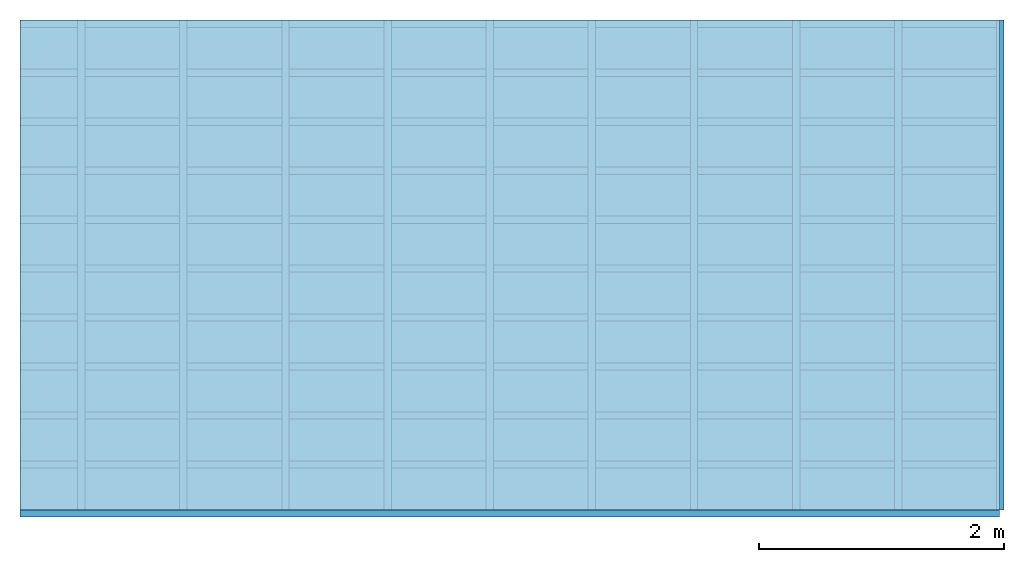
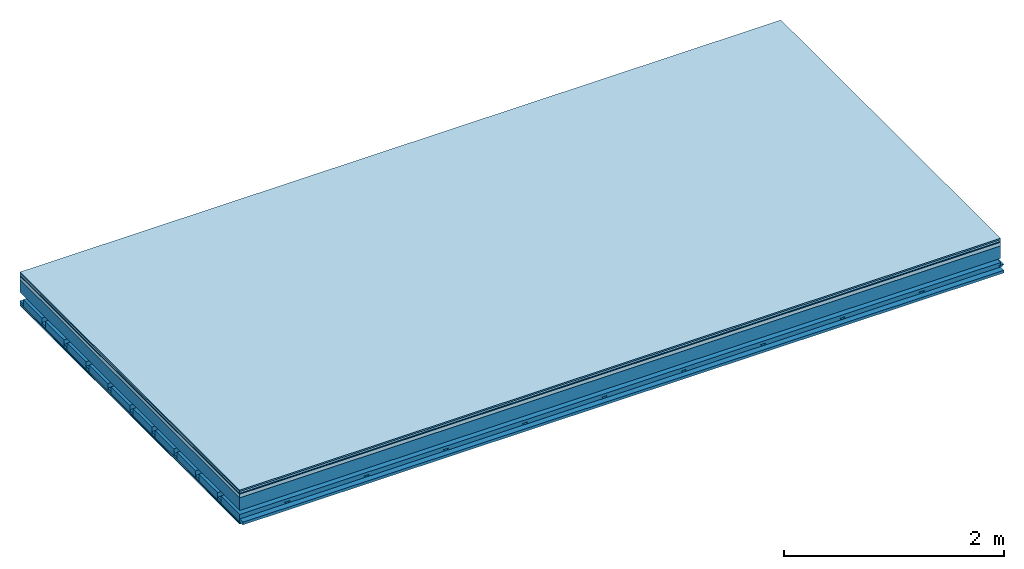
# One storey: 7 plates, 4 members, 1 element without a shape of its own.
"""IFC4 building model written with IfcOpenShell, lengths in metres."""

from ifc_helpers import new_model, si_unit, derived_unit, direction, frame, frame_2d, origin, origin_with_axes, place, context, project, spatial, polyline, rectangle, outline, extrude, material, layer, layer_set, type_object, element, aggregate, save


model = new_model("IFC4")

# Units and contexts
plan_context = context("Plan", 3, precision=1e-05, world=origin(), true_north=direction((0.0, 1.0)))
model_context = context("Model", 3, precision=1e-05, world=origin(), true_north=direction((0.0, 1.0)))
ifc_project = project(units=[si_unit("LENGTHUNIT", "METRE"), derived_unit("SOUNDPRESSUREUNIT", [(si_unit("PRESSUREUNIT", "PASCAL", prefix="MICRO"), 0)]), si_unit("ENERGYUNIT", "JOULE", prefix="MEGA"), si_unit("MASSUNIT", "GRAM", prefix="KILO"), derived_unit("THERMALTRANSMITTANCEUNIT", [(si_unit("POWERUNIT", "WATT"), 1), (si_unit("AREAUNIT", "SQUARE_METRE"), -1), (si_unit("THERMODYNAMICTEMPERATUREUNIT", "KELVIN"), -1)]), derived_unit("AREADENSITYUNIT", [(si_unit("MASSUNIT", "GRAM", prefix="KILO"), 1), (si_unit("AREAUNIT", "SQUARE_METRE"), -1)]), derived_unit("USERDEFINED", [(si_unit("ENERGYUNIT", "JOULE", prefix="MEGA"), 1), (si_unit("AREAUNIT", "SQUARE_METRE"), -1)])], contexts=[plan_context, model_context])

# Site, building, storey
site = spatial("IfcSite", under=ifc_project)
building_placement = place(None, origin())
building = spatial("IfcBuilding", under=site, at=building_placement)
storey_placement = place(building_placement, origin())
storey = spatial("IfcBuildingStorey", under=building, at=storey_placement)

# Slab, members, plates
ifc_material_1 = material(Category="11.013")
ifc_layer_1 = layer(ifc_material_1, 0.015, Name="Flooring")
ifc_material_2 = material(Category="03.007")
ifc_layer_2 = layer(ifc_material_2, 0.02, Name="On-material")
ifc_material_3 = material(Name="Wood fiber generic product", Category="10.009")
ifc_layer_3 = layer(ifc_material_3, 0.01, Name="Impact sound insulation")
ifc_material_4 = material(Name="Concrete panels", Category="02.007")
ifc_layer_4 = layer(ifc_material_4, 0.04, Name="on Supporting structure")
ifc_material_5 = material(Name="no composite action")
ifc_layer_5 = layer(ifc_material_5, 0.0, Name="Bond")
ifc_layer_6 = layer(None, 0.14, Name="Supporting structure")
ifc_layer_7 = layer(ifc_material_5, 0.0, Name="Bond")
ifc_layer_8 = layer(None, 0.095, Name="Coupling")
ifc_layer_9 = layer(None, 0.03, Name="Battens / profiles")
ifc_material_6 = material(Name="Plasterboard type A", Category="03.008")
ifc_layer_10 = layer(ifc_material_6, 0.0125, Name="Ceiling covering 1st layer")
ifc_layer_11 = layer(ifc_material_6, 0.0125, Name="Ceiling covering layer 2")
ifc_material_7 = material(Category="04.001")
ifc_layer_12 = layer(ifc_material_7, 0.003, Name="Surface / treatment")
ifc_layer_set = layer_set([ifc_layer_1, ifc_layer_2, ifc_layer_3, ifc_layer_4, ifc_layer_5, ifc_layer_6, ifc_layer_7, ifc_layer_8, ifc_layer_9, ifc_layer_10, ifc_layer_11, ifc_layer_12])
slab_type = type_object("IfcSlabType", Name="A2133", PredefinedType="NOTDEFINED", material=ifc_layer_set)
slab_placement = place(None, frame((0.0, 0.0, 0.0), z_axis=(0.0, 0.0, -1.0), x_axis=(1.0, 0.0, 0.0)))
slab = element("IfcSlab", 1, at=slab_placement, inside=storey, type_object=slab_type, material=ifc_layer_set, Name="Slab #1")
ifc_material_8 = material(Name="Solid timber panel")
member_1_placement = place(slab_placement, origin())
member_1 = element("IfcMember", 2, at=member_1_placement, material=ifc_material_8, Name="Supporting structure", context=plan_context, shape_type="SweptSolid", body=[
    extrude(rectangle(XDim=1.0, YDim=0.14, at=frame_2d((0.5, 0.07), x_axis=(1.0, 0.0))), frame((0.0, 4.0, 0.085), z_axis=(0.0, -1.0, 0.0), x_axis=(1.0, 0.0, 0.0)), (0.0, 0.0, 1.0), 4.0),
    extrude(rectangle(XDim=1.0, YDim=0.14, at=frame_2d((0.5, 0.07), x_axis=(1.0, 0.0))), frame((1.0, 4.0, 0.085), z_axis=(0.0, -1.0, 0.0), x_axis=(1.0, 0.0, 0.0)), (0.0, 0.0, 1.0), 4.0),
    extrude(rectangle(XDim=1.0, YDim=0.14, at=frame_2d((0.5, 0.07), x_axis=(1.0, 0.0))), frame((2.0, 4.0, 0.085), z_axis=(0.0, -1.0, 0.0), x_axis=(1.0, 0.0, 0.0)), (0.0, 0.0, 1.0), 4.0),
    extrude(rectangle(XDim=1.0, YDim=0.14, at=frame_2d((0.5, 0.07), x_axis=(1.0, 0.0))), frame((3.0, 4.0, 0.085), z_axis=(0.0, -1.0, 0.0), x_axis=(1.0, 0.0, 0.0)), (0.0, 0.0, 1.0), 4.0),
    extrude(rectangle(XDim=1.0, YDim=0.14, at=frame_2d((0.5, 0.07), x_axis=(1.0, 0.0))), frame((4.0, 4.0, 0.085), z_axis=(0.0, -1.0, 0.0), x_axis=(1.0, 0.0, 0.0)), (0.0, 0.0, 1.0), 4.0),
    extrude(rectangle(XDim=1.0, YDim=0.14, at=frame_2d((0.5, 0.07), x_axis=(1.0, 0.0))), frame((5.0, 4.0, 0.085), z_axis=(0.0, -1.0, 0.0), x_axis=(1.0, 0.0, 0.0)), (0.0, 0.0, 1.0), 4.0),
    extrude(rectangle(XDim=1.0, YDim=0.14, at=frame_2d((0.5, 0.07), x_axis=(1.0, 0.0))), frame((6.0, 4.0, 0.085), z_axis=(0.0, -1.0, 0.0), x_axis=(1.0, 0.0, 0.0)), (0.0, 0.0, 1.0), 4.0),
    extrude(rectangle(XDim=1.0, YDim=0.14, at=frame_2d((0.5, 0.07), x_axis=(1.0, 0.0))), frame((7.0, 4.0, 0.085), z_axis=(0.0, -1.0, 0.0), x_axis=(1.0, 0.0, 0.0)), (0.0, 0.0, 1.0), 4.0),
])
ifc_material_9 = material()
member_2_placement = place(slab_placement, origin())
member_2 = element("IfcMember", 3, at=member_2_placement, material=ifc_material_9, Name="Coupling", context=plan_context, shape_type="SweptSolid", body=[
    extrude(outline(polyline([(0.0, 0.0), (0.06, 0.0), (0.04, 0.02), (0.02, 0.02), (0.0, 0.0)])), frame((0.47, 4.0, 0.3), z_axis=(0.0, -1.0, 0.0), x_axis=(1.0, 0.0, 0.0)), (0.0, 0.0, 1.0), 4.0),
    extrude(outline(polyline([(0.0, 0.0), (0.06, 0.0), (0.04, 0.02), (0.02, 0.02), (0.0, 0.0)])), frame((1.304, 4.0, 0.3), z_axis=(0.0, -1.0, 0.0), x_axis=(1.0, 0.0, 0.0)), (0.0, 0.0, 1.0), 4.0),
    extrude(outline(polyline([(0.0, 0.0), (0.06, 0.0), (0.04, 0.02), (0.02, 0.02), (0.0, 0.0)])), frame((2.138, 4.0, 0.3), z_axis=(0.0, -1.0, 0.0), x_axis=(1.0, 0.0, 0.0)), (0.0, 0.0, 1.0), 4.0),
    extrude(outline(polyline([(0.0, 0.0), (0.06, 0.0), (0.04, 0.02), (0.02, 0.02), (0.0, 0.0)])), frame((2.972, 4.0, 0.3), z_axis=(0.0, -1.0, 0.0), x_axis=(1.0, 0.0, 0.0)), (0.0, 0.0, 1.0), 4.0),
    extrude(outline(polyline([(0.0, 0.0), (0.06, 0.0), (0.04, 0.02), (0.02, 0.02), (0.0, 0.0)])), frame((3.806, 4.0, 0.3), z_axis=(0.0, -1.0, 0.0), x_axis=(1.0, 0.0, 0.0)), (0.0, 0.0, 1.0), 4.0),
    extrude(outline(polyline([(0.0, 0.0), (0.06, 0.0), (0.04, 0.02), (0.02, 0.02), (0.0, 0.0)])), frame((4.64, 4.0, 0.3), z_axis=(0.0, -1.0, 0.0), x_axis=(1.0, 0.0, 0.0)), (0.0, 0.0, 1.0), 4.0),
    extrude(outline(polyline([(0.0, 0.0), (0.06, 0.0), (0.04, 0.02), (0.02, 0.02), (0.0, 0.0)])), frame((5.474, 4.0, 0.3), z_axis=(0.0, -1.0, 0.0), x_axis=(1.0, 0.0, 0.0)), (0.0, 0.0, 1.0), 4.0),
    extrude(outline(polyline([(0.0, 0.0), (0.06, 0.0), (0.04, 0.02), (0.02, 0.02), (0.0, 0.0)])), frame((6.308, 4.0, 0.3), z_axis=(0.0, -1.0, 0.0), x_axis=(1.0, 0.0, 0.0)), (0.0, 0.0, 1.0), 4.0),
    extrude(outline(polyline([(0.0, 0.0), (0.06, 0.0), (0.04, 0.02), (0.02, 0.02), (0.0, 0.0)])), frame((7.142, 4.0, 0.3), z_axis=(0.0, -1.0, 0.0), x_axis=(1.0, 0.0, 0.0)), (0.0, 0.0, 1.0), 4.0),
    extrude(outline(polyline([(0.0, 0.0), (0.06, 0.0), (0.04, 0.02), (0.02, 0.02), (0.0, 0.0)])), frame((7.976, 4.0, 0.3), z_axis=(0.0, -1.0, 0.0), x_axis=(1.0, 0.0, 0.0)), (0.0, 0.0, 1.0), 4.0),
])
member_3_placement = place(slab_placement, origin())
member_3 = element("IfcMember", 4, at=member_3_placement, material=ifc_material_9, Name="Battens / profiles", context=plan_context, shape_type="SweptSolid", body=[
    extrude(rectangle(XDim=0.06, YDim=0.03, at=frame_2d((0.03, 0.015), x_axis=(1.0, 0.0))), frame((0.0, 0.0, 0.32), z_axis=(1.0, 0.0, 0.0), x_axis=(0.0, 1.0, 0.0)), (0.0, 0.0, 1.0), 8.0),
    extrude(rectangle(XDim=0.06, YDim=0.03, at=frame_2d((0.03, 0.015), x_axis=(1.0, 0.0))), frame((0.0, 0.4, 0.32), z_axis=(1.0, 0.0, 0.0), x_axis=(0.0, 1.0, 0.0)), (0.0, 0.0, 1.0), 8.0),
    extrude(rectangle(XDim=0.06, YDim=0.03, at=frame_2d((0.03, 0.015), x_axis=(1.0, 0.0))), frame((0.0, 0.8, 0.32), z_axis=(1.0, 0.0, 0.0), x_axis=(0.0, 1.0, 0.0)), (0.0, 0.0, 1.0), 8.0),
    extrude(rectangle(XDim=0.06, YDim=0.03, at=frame_2d((0.03, 0.015), x_axis=(1.0, 0.0))), frame((0.0, 1.2, 0.32), z_axis=(1.0, 0.0, 0.0), x_axis=(0.0, 1.0, 0.0)), (0.0, 0.0, 1.0), 8.0),
    extrude(rectangle(XDim=0.06, YDim=0.03, at=frame_2d((0.03, 0.015), x_axis=(1.0, 0.0))), frame((0.0, 1.6, 0.32), z_axis=(1.0, 0.0, 0.0), x_axis=(0.0, 1.0, 0.0)), (0.0, 0.0, 1.0), 8.0),
    extrude(rectangle(XDim=0.06, YDim=0.03, at=frame_2d((0.03, 0.015), x_axis=(1.0, 0.0))), frame((0.0, 2.0, 0.32), z_axis=(1.0, 0.0, 0.0), x_axis=(0.0, 1.0, 0.0)), (0.0, 0.0, 1.0), 8.0),
    extrude(rectangle(XDim=0.06, YDim=0.03, at=frame_2d((0.03, 0.015), x_axis=(1.0, 0.0))), frame((0.0, 2.4, 0.32), z_axis=(1.0, 0.0, 0.0), x_axis=(0.0, 1.0, 0.0)), (0.0, 0.0, 1.0), 8.0),
    extrude(rectangle(XDim=0.06, YDim=0.03, at=frame_2d((0.03, 0.015), x_axis=(1.0, 0.0))), frame((0.0, 2.8, 0.32), z_axis=(1.0, 0.0, 0.0), x_axis=(0.0, 1.0, 0.0)), (0.0, 0.0, 1.0), 8.0),
    extrude(rectangle(XDim=0.06, YDim=0.03, at=frame_2d((0.03, 0.015), x_axis=(1.0, 0.0))), frame((0.0, 3.2, 0.32), z_axis=(1.0, 0.0, 0.0), x_axis=(0.0, 1.0, 0.0)), (0.0, 0.0, 1.0), 8.0),
    extrude(rectangle(XDim=0.06, YDim=0.03, at=frame_2d((0.03, 0.015), x_axis=(1.0, 0.0))), frame((0.0, 3.6, 0.32), z_axis=(1.0, 0.0, 0.0), x_axis=(0.0, 1.0, 0.0)), (0.0, 0.0, 1.0), 8.0),
    extrude(rectangle(XDim=0.06, YDim=0.03, at=frame_2d((0.03, 0.015), x_axis=(1.0, 0.0))), frame((0.0, 4.0, 0.32), z_axis=(1.0, 0.0, 0.0), x_axis=(0.0, 1.0, 0.0)), (0.0, 0.0, 1.0), 8.0),
])
ifc_material_10 = material()
member_4_placement = place(slab_placement, origin())
member_4 = element("IfcMember", 5, at=member_4_placement, material=ifc_material_10, Name="Cavity", context=plan_context, shape_type="SweptSolid", body=[
    extrude(rectangle(XDim=0.34, YDim=0.08, at=frame_2d((0.17, 0.04), x_axis=(1.0, 0.0))), frame((0.0, 0.06, 0.27), z_axis=(1.0, 0.0, 0.0), x_axis=(0.0, 1.0, 0.0)), (0.0, 0.0, 1.0), 8.0),
    extrude(rectangle(XDim=0.34, YDim=0.08, at=frame_2d((0.17, 0.04), x_axis=(1.0, 0.0))), frame((0.0, 0.46, 0.27), z_axis=(1.0, 0.0, 0.0), x_axis=(0.0, 1.0, 0.0)), (0.0, 0.0, 1.0), 8.0),
    extrude(rectangle(XDim=0.34, YDim=0.08, at=frame_2d((0.17, 0.04), x_axis=(1.0, 0.0))), frame((0.0, 0.86, 0.27), z_axis=(1.0, 0.0, 0.0), x_axis=(0.0, 1.0, 0.0)), (0.0, 0.0, 1.0), 8.0),
    extrude(rectangle(XDim=0.34, YDim=0.08, at=frame_2d((0.17, 0.04), x_axis=(1.0, 0.0))), frame((0.0, 1.26, 0.27), z_axis=(1.0, 0.0, 0.0), x_axis=(0.0, 1.0, 0.0)), (0.0, 0.0, 1.0), 8.0),
    extrude(rectangle(XDim=0.34, YDim=0.08, at=frame_2d((0.17, 0.04), x_axis=(1.0, 0.0))), frame((0.0, 1.66, 0.27), z_axis=(1.0, 0.0, 0.0), x_axis=(0.0, 1.0, 0.0)), (0.0, 0.0, 1.0), 8.0),
    extrude(rectangle(XDim=0.34, YDim=0.08, at=frame_2d((0.17, 0.04), x_axis=(1.0, 0.0))), frame((0.0, 2.06, 0.27), z_axis=(1.0, 0.0, 0.0), x_axis=(0.0, 1.0, 0.0)), (0.0, 0.0, 1.0), 8.0),
    extrude(rectangle(XDim=0.34, YDim=0.08, at=frame_2d((0.17, 0.04), x_axis=(1.0, 0.0))), frame((0.0, 2.46, 0.27), z_axis=(1.0, 0.0, 0.0), x_axis=(0.0, 1.0, 0.0)), (0.0, 0.0, 1.0), 8.0),
    extrude(rectangle(XDim=0.34, YDim=0.08, at=frame_2d((0.17, 0.04), x_axis=(1.0, 0.0))), frame((0.0, 2.86, 0.27), z_axis=(1.0, 0.0, 0.0), x_axis=(0.0, 1.0, 0.0)), (0.0, 0.0, 1.0), 8.0),
    extrude(rectangle(XDim=0.34, YDim=0.08, at=frame_2d((0.17, 0.04), x_axis=(1.0, 0.0))), frame((0.0, 3.26, 0.27), z_axis=(1.0, 0.0, 0.0), x_axis=(0.0, 1.0, 0.0)), (0.0, 0.0, 1.0), 8.0),
    extrude(rectangle(XDim=0.34, YDim=0.08, at=frame_2d((0.17, 0.04), x_axis=(1.0, 0.0))), frame((0.0, 3.66, 0.27), z_axis=(1.0, 0.0, 0.0), x_axis=(0.0, 1.0, 0.0)), (0.0, 0.0, 1.0), 8.0),
])
plate_1_placement = place(slab_placement, origin())
plate_1 = element("IfcPlate", 6, at=plate_1_placement, material=ifc_material_1, Name="Flooring", context=plan_context, shape_type="SweptSolid", body=[
    extrude(rectangle(XDim=8.0, YDim=4.0, at=frame_2d((4.0, 2.0), x_axis=(1.0, 0.0))), origin_with_axes(), (0.0, 0.0, 1.0), 0.015),
])
plate_2_placement = place(slab_placement, origin())
plate_2 = element("IfcPlate", 7, at=plate_2_placement, material=ifc_material_2, Name="On-material", context=plan_context, shape_type="SweptSolid", body=[
    extrude(rectangle(XDim=8.0, YDim=4.0, at=frame_2d((4.0, 2.0), x_axis=(1.0, 0.0))), frame((0.0, 0.0, 0.015), z_axis=(0.0, 0.0, 1.0), x_axis=(1.0, 0.0, 0.0)), (0.0, 0.0, 1.0), 0.02),
])
plate_3_placement = place(slab_placement, origin())
plate_3 = element("IfcPlate", 8, at=plate_3_placement, material=ifc_material_3, Name="Impact sound insulation", context=plan_context, shape_type="SweptSolid", body=[
    extrude(rectangle(XDim=8.0, YDim=4.0, at=frame_2d((4.0, 2.0), x_axis=(1.0, 0.0))), frame((0.0, 0.0, 0.035), z_axis=(0.0, 0.0, 1.0), x_axis=(1.0, 0.0, 0.0)), (0.0, 0.0, 1.0), 0.01),
])
plate_4_placement = place(slab_placement, origin())
plate_4 = element("IfcPlate", 9, at=plate_4_placement, material=ifc_material_4, Name="on Supporting structure", context=plan_context, shape_type="SweptSolid", body=[
    extrude(rectangle(XDim=8.0, YDim=4.0, at=frame_2d((4.0, 2.0), x_axis=(1.0, 0.0))), frame((0.0, 0.0, 0.045), z_axis=(0.0, 0.0, 1.0), x_axis=(1.0, 0.0, 0.0)), (0.0, 0.0, 1.0), 0.04),
])
plate_5_placement = place(slab_placement, origin())
plate_5 = element("IfcPlate", 10, at=plate_5_placement, material=ifc_material_6, Name="Ceiling covering 1st layer", context=plan_context, shape_type="SweptSolid", body=[
    extrude(rectangle(XDim=8.0, YDim=4.0, at=frame_2d((4.0, 2.0), x_axis=(1.0, 0.0))), frame((0.0, 0.0, 0.35), z_axis=(0.0, 0.0, 1.0), x_axis=(1.0, 0.0, 0.0)), (0.0, 0.0, 1.0), 0.0125),
])
plate_6_placement = place(slab_placement, origin())
plate_6 = element("IfcPlate", 11, at=plate_6_placement, material=ifc_material_6, Name="Ceiling covering layer 2", context=plan_context, shape_type="SweptSolid", body=[
    extrude(rectangle(XDim=8.0, YDim=4.0, at=frame_2d((4.0, 2.0), x_axis=(1.0, 0.0))), frame((0.0, 0.0, 0.3625), z_axis=(0.0, 0.0, 1.0), x_axis=(1.0, 0.0, 0.0)), (0.0, 0.0, 1.0), 0.0125),
])
plate_7_placement = place(slab_placement, origin())
plate_7 = element("IfcPlate", 12, at=plate_7_placement, material=ifc_material_7, Name="Surface / treatment", context=plan_context, shape_type="SweptSolid", body=[
    extrude(rectangle(XDim=8.0, YDim=4.0, at=frame_2d((4.0, 2.0), x_axis=(1.0, 0.0))), frame((0.0, 0.0, 0.375), z_axis=(0.0, 0.0, 1.0), x_axis=(1.0, 0.0, 0.0)), (0.0, 0.0, 1.0), 0.003),
])
aggregate(slab, [plate_1, plate_2, plate_3, plate_4, member_1, member_2, member_3, member_4, plate_5, plate_6, plate_7])

save(model, "model.ifc")
